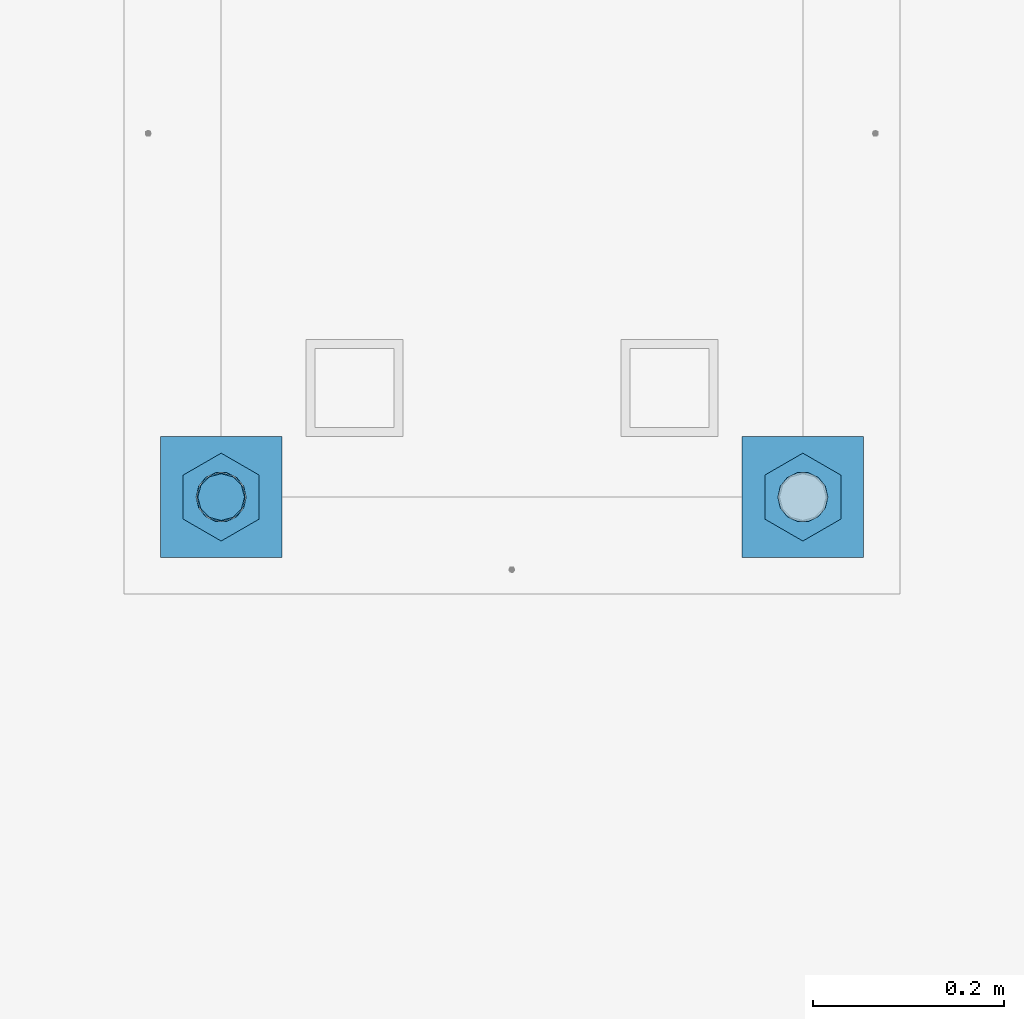
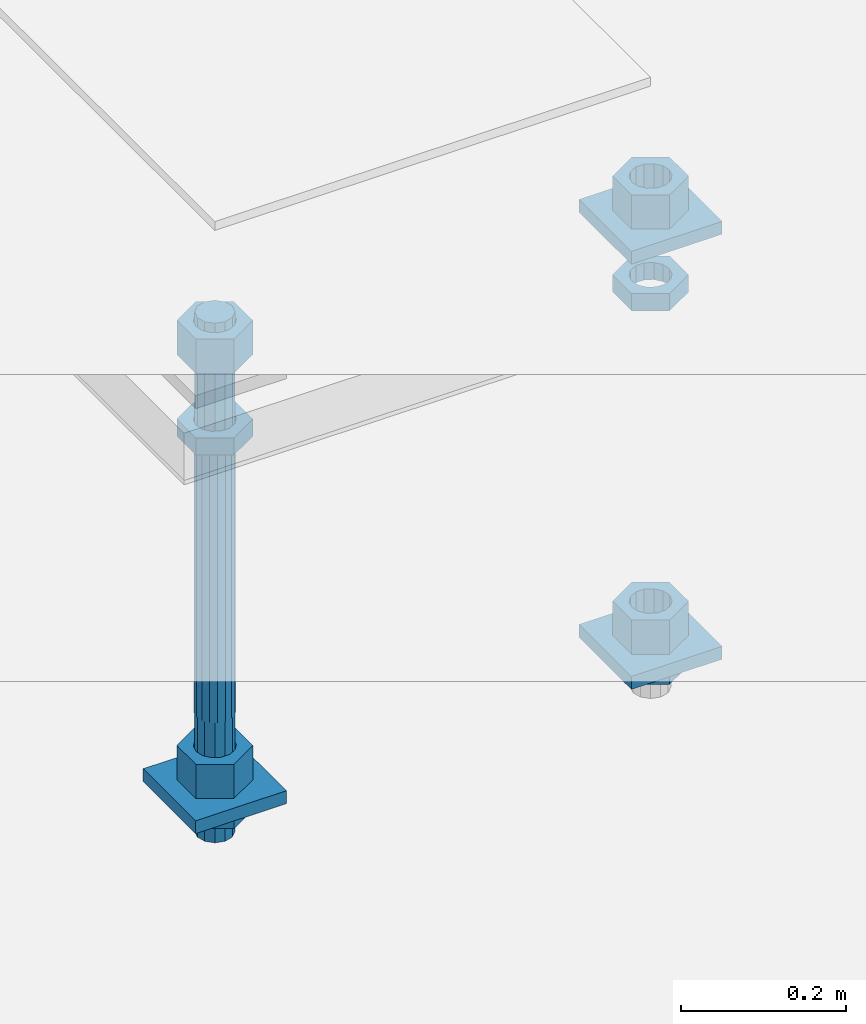
# One storey, part 2642 of 3843: 12 beams, 1 element without a shape of its own.
"""IFC2X3 building model written with IfcOpenShell, lengths in millimetres."""

import ifcopenshell
import ifcopenshell.guid

model = None  # the IFC model being written
_history = None  # IfcOwnerHistory: only IFC2X3 demands one
_inside = {}  # id of a spatial element -> (the spatial element, [elements in it])
_under = {}  # id of a project, library or spatial element -> (it, [spatial elements below it])
_declared = {}  # id of a project -> (the project, [libraries it declares])
_typed = {}  # id of a type object -> (the type object, [elements of that type])
_made_of = {}  # id of a material, layer set ... -> (it, [elements and type objects made of it])


def new_model(schema):
    """Start an empty IFC model of exactly this schema.

    Asked for "IFC4X3", IfcOpenShell would pick the latest addendum, in which some entities
    have other attributes; the version numbers below select the first issue.
    IFC2X3 requires an IfcOwnerHistory on every rooted entity: one is made here for all.
    """
    global model, _history
    if schema == "IFC4X3":
        model = ifcopenshell.file(schema_version=(4, 3, 0, 0))
    else:
        model = ifcopenshell.file(schema=schema)
    _inside.clear()
    _under.clear()
    _declared.clear()
    _typed.clear()
    _made_of.clear()
    _history = None
    if model.schema == "IFC2X3":
        org = make("IfcOrganization", Name="unknown")
        user = make(
            "IfcPersonAndOrganization",
            ThePerson=make("IfcPerson", FamilyName="unknown"),
            TheOrganization=org,
        )
        app = make(
            "IfcApplication",
            ApplicationDeveloper=org,
            Version="unknown",
            ApplicationFullName="unknown",
            ApplicationIdentifier="unknown",
        )
        _history = make(
            "IfcOwnerHistory",
            OwningUser=user,
            OwningApplication=app,
            ChangeAction="ADDED",
            CreationDate=0,
        )
    return model


def make(cls, **values):
    """One entity of the class cls with the attributes given. An attribute that is None is left unset."""
    return model.create_entity(
        cls, **{name: value for name, value in values.items() if value is not None}
    )


def rooted(cls, **values):
    """An entity with a GlobalId (a new one), such as an element, a storey or a relation."""
    return make(cls, GlobalId=ifcopenshell.guid.new(), OwnerHistory=_history, **values)


def si_unit(unit_type, name, prefix=None):
    """IfcSIUnit, for example si_unit("LENGTHUNIT", "METRE", prefix="MILLI")."""
    return make("IfcSIUnit", UnitType=unit_type, Prefix=prefix, Name=name)


def assignment(units):
    """IfcUnitAssignment: the units of a project."""
    return None if units is None else make("IfcUnitAssignment", Units=units)


def point(xyz):
    """IfcCartesianPoint."""
    return None if xyz is None else make("IfcCartesianPoint", Coordinates=xyz)


def direction(xyz):
    """IfcDirection."""
    return None if xyz is None else make("IfcDirection", DirectionRatios=xyz)


def frame(location, z_axis=None, x_axis=None):
    """IfcAxis2Placement3D, a coordinate frame: its origin and axes. An axis left out is left unset."""
    return make(
        "IfcAxis2Placement3D",
        Location=point(location),
        Axis=direction(z_axis),
        RefDirection=direction(x_axis),
    )


def origin_with_axes():
    """The frame at (0, 0, 0) with the z axis (0, 0, 1) and the x axis (1, 0, 0) written out."""
    return frame((0.0, 0.0, 0.0), z_axis=(0.0, 0.0, 1.0), x_axis=(1.0, 0.0, 0.0))


def place(relative_to, where):
    """IfcLocalPlacement: puts the frame where relative to a parent placement (None: the world)."""
    return make(
        "IfcLocalPlacement", PlacementRelTo=relative_to, RelativePlacement=where
    )


def context(
    kind, dimensions, precision=None, world=None, true_north=None, identifier=None
):
    """IfcGeometricRepresentationContext, for example the 3D "Model" context."""
    return make(
        "IfcGeometricRepresentationContext",
        ContextIdentifier=identifier,
        ContextType=kind,
        CoordinateSpaceDimension=dimensions,
        Precision=precision,
        WorldCoordinateSystem=world,
        TrueNorth=true_north,
    )


def subcontext(parent, identifier, kind, view, scale=None):
    """IfcGeometricRepresentationSubContext, for example "Body" below "Model"."""
    return make(
        "IfcGeometricRepresentationSubContext",
        ContextIdentifier=identifier,
        ContextType=kind,
        ParentContext=parent,
        TargetScale=scale,
        TargetView=view,
    )


def project(units=None, contexts=None):
    """IfcProject with its units and contexts."""
    return rooted(
        "IfcProject",
        Name="project",
        RepresentationContexts=contexts,
        UnitsInContext=assignment(units),
    )


def spatial(cls, under=None, at=None, **own):
    """A site, building, storey or space (cls), placed at a placement, below another one or the project."""
    s = rooted(cls, ObjectPlacement=at, **own)
    if under is not None:
        _under.setdefault(under.id(), (under, []))[1].append(s)
    return s


def faces_of(points, faces, orient=None, outer=None):
    """IfcFace entities. A face is a list of loops; a loop is a list of indices into points, from 0.

    orient and outer hold one flag for each loop. By default every Orientation is true, the
    first loop of a face is its IfcFaceOuterBound and the others are IfcFaceBound.
    """
    made = []
    for i, loops in enumerate(faces):
        bounds = []
        for j, loop in enumerate(loops):
            is_outer = j == 0 if outer is None else outer[i][j]
            bounds.append(
                make(
                    "IfcFaceOuterBound" if is_outer else "IfcFaceBound",
                    Bound=make("IfcPolyLoop", Polygon=[points[k] for k in loop]),
                    Orientation=True if orient is None else orient[i][j],
                )
            )
        made.append(make("IfcFace", Bounds=bounds))
    return made


def faceted_brep(points, faces, orient=None, outer=None, voids=None):
    """IfcFacetedBrep: a solid bounded by flat faces; with voids (closed shells), ...WithVoids."""
    shared = [point(p) for p in points]
    hull = make("IfcClosedShell", CfsFaces=faces_of(shared, faces, orient, outer))
    if voids is None:
        return make("IfcFacetedBrep", Outer=hull)
    return make(
        "IfcFacetedBrepWithVoids",
        Outer=hull,
        Voids=[
            make(cls, CfsFaces=faces_of(shared, fs, o, b)) for cls, fs, o, b in voids
        ],
    )


def shape(context_of_items, identifier, shape_type, items):
    """IfcShapeRepresentation: the items that make up one representation, for example the "Body"."""
    return make(
        "IfcShapeRepresentation",
        ContextOfItems=context_of_items,
        RepresentationIdentifier=identifier,
        RepresentationType=shape_type,
        Items=items,
    )


def material(Name=None, Category=None):
    """IfcMaterial."""
    return make("IfcMaterial", Name=Name, Category=Category)


def made_of(thing, what):
    """Note that an element or type object is made of a material, layer set ...; save() writes the relation."""
    if what is not None:
        _made_of.setdefault(what.id(), (what, []))[1].append(thing)
    return thing


def type_object(cls, material=None, **own):
    """A type object (cls), such as IfcWallType, which elements share."""
    return made_of(rooted(cls, **own), material)


def element(
    cls,
    number,
    at=None,
    inside=None,
    cuts=None,
    type_object=None,
    material=None,
    context=None,
    identifier="Body",
    shape_type=None,
    held_by="IfcProductDefinitionShape",
    body=None,
    shapes=None,
    **own,
):
    """One element of the class cls, such as IfcWall. Its Tag is "e" and its number.

    at: its placement. inside: the storey or other place that contains it. cuts: it is an
    opening in that element (IfcRelVoidsElement). A single representation is given by context,
    identifier, shape_type and body (its items); several are given by shapes. held_by: the class
    of the entity that holds the representations. save() writes the other relations.
    """
    e = rooted(cls, Tag="e%d" % number, ObjectPlacement=at, **own)
    if body is not None:
        shapes = [shape(context, identifier, shape_type, body)]
    if shapes is not None:
        e.Representation = make(held_by, Representations=shapes)
    if inside is not None:
        _inside.setdefault(inside.id(), (inside, []))[1].append(e)
    if cuts is not None:
        rooted(
            "IfcRelVoidsElement", RelatingBuildingElement=cuts, RelatedOpeningElement=e
        )
    if type_object is not None:
        _typed.setdefault(type_object.id(), (type_object, []))[1].append(e)
    return made_of(e, material)


def aggregate(whole, parts):
    """IfcRelAggregates: a whole, such as a stair, and the parts it consists of."""
    return rooted("IfcRelAggregates", RelatingObject=whole, RelatedObjects=parts)


def save(model, path):
    """Write the relations noted so far, then the file.

    IfcRelAggregates (storeys below a building ...), IfcRelContainedInSpatialStructure (elements
    in a storey), IfcRelDefinesByType, IfcRelAssociatesMaterial and IfcRelDeclares: one each for
    every whole, place, type object, material and project.
    """
    for whole, parts in _under.values():
        aggregate(whole, parts)
    for where, things in _inside.values():
        rooted(
            "IfcRelContainedInSpatialStructure",
            RelatedElements=things,
            RelatingStructure=where,
        )
    for kind, things in _typed.values():
        rooted("IfcRelDefinesByType", RelatedObjects=things, RelatingType=kind)
    for what, things in _made_of.values():
        rooted("IfcRelAssociatesMaterial", RelatedObjects=things, RelatingMaterial=what)
    for by, libraries in _declared.values():
        rooted("IfcRelDeclares", RelatingContext=by, RelatedDefinitions=libraries)
    model.write(path)


model = new_model("IFC2X3")

# Units and contexts
model_context = context("Model", 3, precision=1e-05, world=origin_with_axes())
body_context = subcontext(model_context, "Body", "Model", "MODEL_VIEW")
ifc_project = project(units=[si_unit("LENGTHUNIT", "METRE", prefix="MILLI"), si_unit("AREAUNIT", "SQUARE_METRE"), si_unit("VOLUMEUNIT", "CUBIC_METRE"), si_unit("MASSUNIT", "GRAM", prefix="KILO"), si_unit("TIMEUNIT", "SECOND"), si_unit("PLANEANGLEUNIT", "RADIAN"), si_unit("SOLIDANGLEUNIT", "STERADIAN"), si_unit("THERMODYNAMICTEMPERATUREUNIT", "DEGREE_CELSIUS"), si_unit("LUMINOUSINTENSITYUNIT", "LUMEN")], contexts=[model_context])

# Site, building, storey
site_placement = place(None, origin_with_axes())
site = spatial("IfcSite", under=ifc_project, at=site_placement, CompositionType="ELEMENT")
building_placement = place(site_placement, origin_with_axes())
building = spatial("IfcBuilding", under=site, at=building_placement, Name="Undefined", CompositionType="ELEMENT")
storey_placement = place(building_placement, origin_with_axes())
storey = spatial("IfcBuildingStorey", under=building, at=storey_placement, Name="Undefined", CompositionType="ELEMENT", Elevation=0.0)

# Assembly, beams
assembly_placement = place(storey_placement, origin_with_axes())
assembly = element("IfcElementAssembly", 1, at=assembly_placement, inside=storey, Name="TEMPLATE", AssemblyPlace="NOTDEFINED", PredefinedType="RIGID_FRAME")
ifc_material_1 = material(Name="STEEL/A36")
beam_type_1 = type_object("IfcBeamType", PredefinedType="NOTDEFINED")
beam_1_placement = place(assembly_placement, frame((116471.7, 10121.9, 29873.575), z_axis=(0.0, 1.0, 0.0), x_axis=(-1.0, 0.0, 0.0)))
beam_1 = element("IfcBeam", 2, at=beam_1_placement, type_object=beam_type_1, material=ifc_material_1, Name="WASHER_PLATE", context=body_context, shape_type="Brep", body=[
    faceted_brep([(0.0, 9.52500000000146, -63.5), (0.0, 9.52500000000146, 63.5), (127.0, 9.52500000000146, 63.5), (127.0, 9.52500000000146, -63.5), (0.0, -9.52500000000146, 63.5), (127.0, -9.52500000000146, 63.5), (0.0, -9.52500000000146, -63.5), (127.0, -9.52500000000146, -63.5)], [[[0, 1, 2, 3]], [[1, 4, 5, 2]], [[4, 6, 7, 5]], [[6, 0, 3, 7]], [[5, 7, 3, 2]], [[6, 4, 1, 0]]]),
])
beam_2_placement = place(assembly_placement, frame((115862.099998474, 10121.9, 29244.925), z_axis=(0.0, 1.0, 0.0), x_axis=(-1.0, 0.0, 0.0)))
beam_2 = element("IfcBeam", 3, at=beam_2_placement, type_object=beam_type_1, material=ifc_material_1, Name="WASHER_PLATE", context=body_context, shape_type="Brep", body=[
    faceted_brep([(0.0, 9.52500000000146, -63.5), (0.0, 9.52500000000146, 63.5), (127.0, 9.52500000000146, 63.5), (127.0, 9.52500000000146, -63.5), (0.0, -9.52500000000146, 63.5), (127.0, -9.52500000000146, 63.5), (0.0, -9.52500000000146, -63.5), (127.0, -9.52500000000146, -63.5)], [[[0, 1, 2, 3]], [[1, 4, 5, 2]], [[4, 6, 7, 5]], [[6, 0, 3, 7]], [[5, 7, 3, 2]], [[6, 4, 1, 0]]]),
])
beam_3_placement = place(assembly_placement, frame((116471.7, 10121.9, 29244.925), z_axis=(0.0, 1.0, 0.0), x_axis=(-1.0, 0.0, 0.0)))
beam_3 = element("IfcBeam", 4, at=beam_3_placement, type_object=beam_type_1, material=ifc_material_1, Name="WASHER_PLATE", context=body_context, shape_type="Brep", body=[
    faceted_brep([(0.0, 9.52500000000146, -63.5), (0.0, 9.52500000000146, 63.5), (127.0, 9.52500000000146, 63.5), (127.0, 9.52500000000146, -63.5), (0.0, -9.52500000000146, 63.5), (127.0, -9.52500000000146, 63.5), (0.0, -9.52500000000146, -63.5), (127.0, -9.52500000000146, -63.5)], [[[0, 1, 2, 3]], [[1, 4, 5, 2]], [[4, 6, 7, 5]], [[6, 0, 3, 7]], [[5, 7, 3, 2]], [[6, 4, 1, 0]]]),
])
beam_type_2 = type_object("IfcBeamType", Name="2_HALF_NUT", PredefinedType="NOTDEFINED")
beam_4_placement = place(assembly_placement, frame((115798.599998474, 10121.9, 29787.85), z_axis=(-1.0, 0.0, 0.0), x_axis=(0.0, 0.0, -1.0)))
beam_4 = element("IfcBeam", 5, at=beam_4_placement, type_object=beam_type_2, material=ifc_material_1, Name="NUT", ObjectType="2_HALF_NUT", context=body_context, shape_type="Brep", body=[
    faceted_brep([(0.0, -46.0369987487793, 0.0), (0.0, -23.0184993743896, -39.869213104248), (25.4000000000015, -23.0184993743896, -39.869213104248), (25.4000000000015, -46.0369987487793, 0.0), (0.0, 23.0184993743896, -39.869213104248), (25.4000000000015, 23.0184993743896, -39.869213104248), (0.0, 46.0369987487793, 0.0), (25.4000000000015, 46.0369987487793, 0.0), (0.0, 23.0184993743896, 39.869213104248), (25.4000000000015, 23.0184993743896, 39.869213104248), (0.0, -23.0184993743896, 39.869213104248), (25.4000000000015, -23.0184993743896, 39.869213104248), (0.0, 0.0, 26.1940002441406), (0.0, 11.3650617044477, 23.5999013092805), (25.4000000000015, 11.3650617044477, 23.5999013092805), (25.4000000000015, 0.0, 26.1940002441406), (0.0, 20.4791109456419, 16.3316083006721), (25.4000000000015, 20.4791109456419, 16.3316083006721), (0.0, 25.5370200498292, 5.82867859874386), (25.4000000000015, 25.5370200498292, 5.82867859874386), (0.0, 25.5370200498292, -5.82867859874386), (25.4000000000015, 25.5370200498292, -5.82867859874386), (0.0, 20.4791109456419, -16.3316083006721), (25.4000000000015, 20.4791109456419, -16.3316083006721), (0.0, 11.3650617044477, -23.5999013092805), (25.4000000000015, 11.3650617044477, -23.5999013092805), (0.0, 0.0, -26.1940002441406), (25.4000000000015, 0.0, -26.1940002441406), (0.0, -11.3650617044477, -23.5999013092805), (25.4000000000015, -11.3650617044477, -23.5999013092805), (0.0, -20.4791109456419, -16.3316083006721), (25.4000000000015, -20.4791109456419, -16.3316083006721), (0.0, -25.5370200498292, -5.82867859874386), (25.4000000000015, -25.5370200498292, -5.82867859874386), (0.0, -25.5370200498292, 5.82867859874386), (25.4000000000015, -25.5370200498292, 5.82867859874386), (0.0, -20.4791109456419, 16.3316083006721), (25.4000000000015, -20.4791109456419, 16.3316083006721), (0.0, -11.3650617044477, 23.5999013092805), (25.4000000000015, -11.3650617044477, 23.5999013092805)], [[[0, 1, 2, 3]], [[1, 4, 5, 2]], [[4, 6, 7, 5]], [[6, 8, 9, 7]], [[8, 10, 11, 9]], [[10, 0, 3, 11]], [[12, 13, 14, 15]], [[13, 16, 17, 14]], [[16, 18, 19, 17]], [[18, 20, 21, 19]], [[20, 22, 23, 21]], [[22, 24, 25, 23]], [[24, 26, 27, 25]], [[26, 28, 29, 27]], [[28, 30, 31, 29]], [[30, 32, 33, 31]], [[32, 34, 35, 33]], [[34, 36, 37, 35]], [[36, 38, 39, 37]], [[38, 12, 15, 39]], [[5, 7, 9, 11, 3, 2], [17, 19, 21, 23, 25, 27, 29, 31, 33, 35, 37, 39, 15, 14]], [[10, 8, 6, 4, 1, 0], [38, 36, 34, 32, 30, 28, 26, 24, 22, 20, 18, 16, 13, 12]]]),
])
beam_5_placement = place(assembly_placement, frame((115798.599998474, 10121.9, 29235.4), z_axis=(-1.0, 0.0, 0.0), x_axis=(0.0, 0.0, -1.0)))
beam_5 = element("IfcBeam", 6, at=beam_5_placement, type_object=beam_type_2, material=ifc_material_1, Name="NUT", ObjectType="2_HALF_NUT", context=body_context, shape_type="Brep", body=[
    faceted_brep([(0.0, -46.0369987487793, 0.0), (0.0, -23.0184993743896, -39.869213104248), (25.4000000000015, -23.0184993743896, -39.869213104248), (25.4000000000015, -46.0369987487793, 0.0), (0.0, 23.0184993743896, -39.869213104248), (25.4000000000015, 23.0184993743896, -39.869213104248), (0.0, 46.0369987487793, 0.0), (25.4000000000015, 46.0369987487793, 0.0), (0.0, 23.0184993743896, 39.869213104248), (25.4000000000015, 23.0184993743896, 39.869213104248), (0.0, -23.0184993743896, 39.869213104248), (25.4000000000015, -23.0184993743896, 39.869213104248), (0.0, 0.0, 26.1940002441406), (0.0, 11.3650617044477, 23.5999013092805), (25.4000000000015, 11.3650617044477, 23.5999013092805), (25.4000000000015, 0.0, 26.1940002441406), (0.0, 20.4791109456419, 16.3316083006721), (25.4000000000015, 20.4791109456419, 16.3316083006721), (0.0, 25.5370200498292, 5.82867859874386), (25.4000000000015, 25.5370200498292, 5.82867859874386), (0.0, 25.5370200498292, -5.82867859874386), (25.4000000000015, 25.5370200498292, -5.82867859874386), (0.0, 20.4791109456419, -16.3316083006721), (25.4000000000015, 20.4791109456419, -16.3316083006721), (0.0, 11.3650617044477, -23.5999013092805), (25.4000000000015, 11.3650617044477, -23.5999013092805), (0.0, 0.0, -26.1940002441406), (25.4000000000015, 0.0, -26.1940002441406), (0.0, -11.3650617044477, -23.5999013092805), (25.4000000000015, -11.3650617044477, -23.5999013092805), (0.0, -20.4791109456419, -16.3316083006721), (25.4000000000015, -20.4791109456419, -16.3316083006721), (0.0, -25.5370200498292, -5.82867859874386), (25.4000000000015, -25.5370200498292, -5.82867859874386), (0.0, -25.5370200498292, 5.82867859874386), (25.4000000000015, -25.5370200498292, 5.82867859874386), (0.0, -20.4791109456419, 16.3316083006721), (25.4000000000015, -20.4791109456419, 16.3316083006721), (0.0, -11.3650617044477, 23.5999013092805), (25.4000000000015, -11.3650617044477, 23.5999013092805)], [[[0, 1, 2, 3]], [[1, 4, 5, 2]], [[4, 6, 7, 5]], [[6, 8, 9, 7]], [[8, 10, 11, 9]], [[10, 0, 3, 11]], [[12, 13, 14, 15]], [[13, 16, 17, 14]], [[16, 18, 19, 17]], [[18, 20, 21, 19]], [[20, 22, 23, 21]], [[22, 24, 25, 23]], [[24, 26, 27, 25]], [[26, 28, 29, 27]], [[28, 30, 31, 29]], [[30, 32, 33, 31]], [[32, 34, 35, 33]], [[34, 36, 37, 35]], [[36, 38, 39, 37]], [[38, 12, 15, 39]], [[5, 7, 9, 11, 3, 2], [17, 19, 21, 23, 25, 27, 29, 31, 33, 35, 37, 39, 15, 14]], [[10, 8, 6, 4, 1, 0], [38, 36, 34, 32, 30, 28, 26, 24, 22, 20, 18, 16, 13, 12]]]),
])
beam_6_placement = place(assembly_placement, frame((116408.2, 10121.9, 29787.85), z_axis=(-1.0, 0.0, 0.0), x_axis=(0.0, 0.0, -1.0)))
beam_6 = element("IfcBeam", 7, at=beam_6_placement, type_object=beam_type_2, material=ifc_material_1, Name="NUT", ObjectType="2_HALF_NUT", context=body_context, shape_type="Brep", body=[
    faceted_brep([(0.0, -46.0369987487793, 0.0), (0.0, -23.0184993743896, -39.869213104248), (25.4000000000015, -23.0184993743896, -39.869213104248), (25.4000000000015, -46.0369987487793, 0.0), (0.0, 23.0184993743896, -39.869213104248), (25.4000000000015, 23.0184993743896, -39.869213104248), (0.0, 46.0369987487793, 0.0), (25.4000000000015, 46.0369987487793, 0.0), (0.0, 23.0184993743896, 39.869213104248), (25.4000000000015, 23.0184993743896, 39.869213104248), (0.0, -23.0184993743896, 39.869213104248), (25.4000000000015, -23.0184993743896, 39.869213104248), (0.0, 0.0, 26.1940002441406), (0.0, 11.3650617044477, 23.5999013092805), (25.4000000000015, 11.3650617044477, 23.5999013092805), (25.4000000000015, 0.0, 26.1940002441406), (0.0, 20.4791109456419, 16.3316083006721), (25.4000000000015, 20.4791109456419, 16.3316083006721), (0.0, 25.5370200498292, 5.82867859874386), (25.4000000000015, 25.5370200498292, 5.82867859874386), (0.0, 25.5370200498292, -5.82867859874386), (25.4000000000015, 25.5370200498292, -5.82867859874386), (0.0, 20.4791109456419, -16.3316083006721), (25.4000000000015, 20.4791109456419, -16.3316083006721), (0.0, 11.3650617044477, -23.5999013092805), (25.4000000000015, 11.3650617044477, -23.5999013092805), (0.0, 0.0, -26.1940002441406), (25.4000000000015, 0.0, -26.1940002441406), (0.0, -11.3650617044477, -23.5999013092805), (25.4000000000015, -11.3650617044477, -23.5999013092805), (0.0, -20.4791109456419, -16.3316083006721), (25.4000000000015, -20.4791109456419, -16.3316083006721), (0.0, -25.5370200498292, -5.82867859874386), (25.4000000000015, -25.5370200498292, -5.82867859874386), (0.0, -25.5370200498292, 5.82867859874386), (25.4000000000015, -25.5370200498292, 5.82867859874386), (0.0, -20.4791109456419, 16.3316083006721), (25.4000000000015, -20.4791109456419, 16.3316083006721), (0.0, -11.3650617044477, 23.5999013092805), (25.4000000000015, -11.3650617044477, 23.5999013092805)], [[[0, 1, 2, 3]], [[1, 4, 5, 2]], [[4, 6, 7, 5]], [[6, 8, 9, 7]], [[8, 10, 11, 9]], [[10, 0, 3, 11]], [[12, 13, 14, 15]], [[13, 16, 17, 14]], [[16, 18, 19, 17]], [[18, 20, 21, 19]], [[20, 22, 23, 21]], [[22, 24, 25, 23]], [[24, 26, 27, 25]], [[26, 28, 29, 27]], [[28, 30, 31, 29]], [[30, 32, 33, 31]], [[32, 34, 35, 33]], [[34, 36, 37, 35]], [[36, 38, 39, 37]], [[38, 12, 15, 39]], [[5, 7, 9, 11, 3, 2], [17, 19, 21, 23, 25, 27, 29, 31, 33, 35, 37, 39, 15, 14]], [[10, 8, 6, 4, 1, 0], [38, 36, 34, 32, 30, 28, 26, 24, 22, 20, 18, 16, 13, 12]]]),
])
beam_7_placement = place(assembly_placement, frame((116408.2, 10121.9, 29235.4), z_axis=(-1.0, 0.0, 0.0), x_axis=(0.0, 0.0, -1.0)))
beam_7 = element("IfcBeam", 8, at=beam_7_placement, type_object=beam_type_2, material=ifc_material_1, Name="NUT", ObjectType="2_HALF_NUT", context=body_context, shape_type="Brep", body=[
    faceted_brep([(0.0, -46.0369987487793, 0.0), (0.0, -23.0184993743896, -39.869213104248), (25.4000000000015, -23.0184993743896, -39.869213104248), (25.4000000000015, -46.0369987487793, 0.0), (0.0, 23.0184993743896, -39.869213104248), (25.4000000000015, 23.0184993743896, -39.869213104248), (0.0, 46.0369987487793, 0.0), (25.4000000000015, 46.0369987487793, 0.0), (0.0, 23.0184993743896, 39.869213104248), (25.4000000000015, 23.0184993743896, 39.869213104248), (0.0, -23.0184993743896, 39.869213104248), (25.4000000000015, -23.0184993743896, 39.869213104248), (0.0, 0.0, 26.1940002441406), (0.0, 11.3650617044477, 23.5999013092805), (25.4000000000015, 11.3650617044477, 23.5999013092805), (25.4000000000015, 0.0, 26.1940002441406), (0.0, 20.4791109456419, 16.3316083006721), (25.4000000000015, 20.4791109456419, 16.3316083006721), (0.0, 25.5370200498292, 5.82867859874386), (25.4000000000015, 25.5370200498292, 5.82867859874386), (0.0, 25.5370200498292, -5.82867859874386), (25.4000000000015, 25.5370200498292, -5.82867859874386), (0.0, 20.4791109456419, -16.3316083006721), (25.4000000000015, 20.4791109456419, -16.3316083006721), (0.0, 11.3650617044477, -23.5999013092805), (25.4000000000015, 11.3650617044477, -23.5999013092805), (0.0, 0.0, -26.1940002441406), (25.4000000000015, 0.0, -26.1940002441406), (0.0, -11.3650617044477, -23.5999013092805), (25.4000000000015, -11.3650617044477, -23.5999013092805), (0.0, -20.4791109456419, -16.3316083006721), (25.4000000000015, -20.4791109456419, -16.3316083006721), (0.0, -25.5370200498292, -5.82867859874386), (25.4000000000015, -25.5370200498292, -5.82867859874386), (0.0, -25.5370200498292, 5.82867859874386), (25.4000000000015, -25.5370200498292, 5.82867859874386), (0.0, -20.4791109456419, 16.3316083006721), (25.4000000000015, -20.4791109456419, 16.3316083006721), (0.0, -11.3650617044477, 23.5999013092805), (25.4000000000015, -11.3650617044477, 23.5999013092805)], [[[0, 1, 2, 3]], [[1, 4, 5, 2]], [[4, 6, 7, 5]], [[6, 8, 9, 7]], [[8, 10, 11, 9]], [[10, 0, 3, 11]], [[12, 13, 14, 15]], [[13, 16, 17, 14]], [[16, 18, 19, 17]], [[18, 20, 21, 19]], [[20, 22, 23, 21]], [[22, 24, 25, 23]], [[24, 26, 27, 25]], [[26, 28, 29, 27]], [[28, 30, 31, 29]], [[30, 32, 33, 31]], [[32, 34, 35, 33]], [[34, 36, 37, 35]], [[36, 38, 39, 37]], [[38, 12, 15, 39]], [[5, 7, 9, 11, 3, 2], [17, 19, 21, 23, 25, 27, 29, 31, 33, 35, 37, 39, 15, 14]], [[10, 8, 6, 4, 1, 0], [38, 36, 34, 32, 30, 28, 26, 24, 22, 20, 18, 16, 13, 12]]]),
])
beam_type_3 = type_object("IfcBeamType", Name="2_HEAVY_HEX_NUT", PredefinedType="NOTDEFINED")
beam_8_placement = place(assembly_placement, frame((115798.599998474, 10121.9, 29933.9), z_axis=(-1.0, 0.0, 0.0), x_axis=(0.0, 0.0, -1.0)))
beam_8 = element("IfcBeam", 9, at=beam_8_placement, type_object=beam_type_3, material=ifc_material_1, Name="NUT", ObjectType="2_HEAVY_HEX_NUT", context=body_context, shape_type="Brep", body=[
    faceted_brep([(0.0, -46.0369987487793, 0.0), (0.0, -23.0184993743896, -39.869213104248), (50.7999999999993, -23.0184993743896, -39.869213104248), (50.7999999999993, -46.0369987487793, 0.0), (0.0, 23.0184993743896, -39.869213104248), (50.7999999999993, 23.0184993743896, -39.869213104248), (0.0, 46.0369987487793, 0.0), (50.7999999999993, 46.0369987487793, 0.0), (0.0, 23.0184993743896, 39.869213104248), (50.7999999999993, 23.0184993743896, 39.869213104248), (0.0, -23.0184993743896, 39.869213104248), (50.7999999999993, -23.0184993743896, 39.869213104248), (0.0, 0.0, 26.1940002441406), (0.0, 11.3650617044477, 23.5999013092805), (50.7999999999993, 11.3650617044477, 23.5999013092805), (50.7999999999993, 0.0, 26.1940002441406), (0.0, 20.4791109456419, 16.3316083006721), (50.7999999999993, 20.4791109456419, 16.3316083006721), (0.0, 25.5370200498292, 5.82867859874386), (50.7999999999993, 25.5370200498292, 5.82867859874386), (0.0, 25.5370200498292, -5.82867859874386), (50.7999999999993, 25.5370200498292, -5.82867859874386), (0.0, 20.4791109456419, -16.3316083006721), (50.7999999999993, 20.4791109456419, -16.3316083006721), (0.0, 11.3650617044477, -23.5999013092805), (50.7999999999993, 11.3650617044477, -23.5999013092805), (0.0, 0.0, -26.1940002441406), (50.7999999999993, 0.0, -26.1940002441406), (0.0, -11.3650617044477, -23.5999013092805), (50.7999999999993, -11.3650617044477, -23.5999013092805), (0.0, -20.4791109456419, -16.3316083006721), (50.7999999999993, -20.4791109456419, -16.3316083006721), (0.0, -25.5370200498292, -5.82867859874386), (50.7999999999993, -25.5370200498292, -5.82867859874386), (0.0, -25.5370200498292, 5.82867859874386), (50.7999999999993, -25.5370200498292, 5.82867859874386), (0.0, -20.4791109456419, 16.3316083006721), (50.7999999999993, -20.4791109456419, 16.3316083006721), (0.0, -11.3650617044477, 23.5999013092805), (50.7999999999993, -11.3650617044477, 23.5999013092805)], [[[0, 1, 2, 3]], [[1, 4, 5, 2]], [[4, 6, 7, 5]], [[6, 8, 9, 7]], [[8, 10, 11, 9]], [[10, 0, 3, 11]], [[12, 13, 14, 15]], [[13, 16, 17, 14]], [[16, 18, 19, 17]], [[18, 20, 21, 19]], [[20, 22, 23, 21]], [[22, 24, 25, 23]], [[24, 26, 27, 25]], [[26, 28, 29, 27]], [[28, 30, 31, 29]], [[30, 32, 33, 31]], [[32, 34, 35, 33]], [[34, 36, 37, 35]], [[36, 38, 39, 37]], [[38, 12, 15, 39]], [[5, 7, 9, 11, 3, 2], [17, 19, 21, 23, 25, 27, 29, 31, 33, 35, 37, 39, 15, 14]], [[10, 8, 6, 4, 1, 0], [38, 36, 34, 32, 30, 28, 26, 24, 22, 20, 18, 16, 13, 12]]]),
])
beam_9_placement = place(assembly_placement, frame((115798.599998474, 10121.9, 29305.25), z_axis=(-1.0, 0.0, 0.0), x_axis=(0.0, 0.0, -1.0)))
beam_9 = element("IfcBeam", 10, at=beam_9_placement, type_object=beam_type_3, material=ifc_material_1, Name="NUT", ObjectType="2_HEAVY_HEX_NUT", context=body_context, shape_type="Brep", body=[
    faceted_brep([(0.0, -46.0369987487793, 0.0), (0.0, -23.0184993743896, -39.869213104248), (50.7999999999993, -23.0184993743896, -39.869213104248), (50.7999999999993, -46.0369987487793, 0.0), (0.0, 23.0184993743896, -39.869213104248), (50.7999999999993, 23.0184993743896, -39.869213104248), (0.0, 46.0369987487793, 0.0), (50.7999999999993, 46.0369987487793, 0.0), (0.0, 23.0184993743896, 39.869213104248), (50.7999999999993, 23.0184993743896, 39.869213104248), (0.0, -23.0184993743896, 39.869213104248), (50.7999999999993, -23.0184993743896, 39.869213104248), (0.0, 0.0, 26.1940002441406), (0.0, 11.3650617044477, 23.5999013092805), (50.7999999999993, 11.3650617044477, 23.5999013092805), (50.7999999999993, 0.0, 26.1940002441406), (0.0, 20.4791109456419, 16.3316083006721), (50.7999999999993, 20.4791109456419, 16.3316083006721), (0.0, 25.5370200498292, 5.82867859874386), (50.7999999999993, 25.5370200498292, 5.82867859874386), (0.0, 25.5370200498292, -5.82867859874386), (50.7999999999993, 25.5370200498292, -5.82867859874386), (0.0, 20.4791109456419, -16.3316083006721), (50.7999999999993, 20.4791109456419, -16.3316083006721), (0.0, 11.3650617044477, -23.5999013092805), (50.7999999999993, 11.3650617044477, -23.5999013092805), (0.0, 0.0, -26.1940002441406), (50.7999999999993, 0.0, -26.1940002441406), (0.0, -11.3650617044477, -23.5999013092805), (50.7999999999993, -11.3650617044477, -23.5999013092805), (0.0, -20.4791109456419, -16.3316083006721), (50.7999999999993, -20.4791109456419, -16.3316083006721), (0.0, -25.5370200498292, -5.82867859874386), (50.7999999999993, -25.5370200498292, -5.82867859874386), (0.0, -25.5370200498292, 5.82867859874386), (50.7999999999993, -25.5370200498292, 5.82867859874386), (0.0, -20.4791109456419, 16.3316083006721), (50.7999999999993, -20.4791109456419, 16.3316083006721), (0.0, -11.3650617044477, 23.5999013092805), (50.7999999999993, -11.3650617044477, 23.5999013092805)], [[[0, 1, 2, 3]], [[1, 4, 5, 2]], [[4, 6, 7, 5]], [[6, 8, 9, 7]], [[8, 10, 11, 9]], [[10, 0, 3, 11]], [[12, 13, 14, 15]], [[13, 16, 17, 14]], [[16, 18, 19, 17]], [[18, 20, 21, 19]], [[20, 22, 23, 21]], [[22, 24, 25, 23]], [[24, 26, 27, 25]], [[26, 28, 29, 27]], [[28, 30, 31, 29]], [[30, 32, 33, 31]], [[32, 34, 35, 33]], [[34, 36, 37, 35]], [[36, 38, 39, 37]], [[38, 12, 15, 39]], [[5, 7, 9, 11, 3, 2], [17, 19, 21, 23, 25, 27, 29, 31, 33, 35, 37, 39, 15, 14]], [[10, 8, 6, 4, 1, 0], [38, 36, 34, 32, 30, 28, 26, 24, 22, 20, 18, 16, 13, 12]]]),
])
beam_10_placement = place(assembly_placement, frame((116408.2, 10121.9, 29933.9), z_axis=(-1.0, 0.0, 0.0), x_axis=(0.0, 0.0, -1.0)))
beam_10 = element("IfcBeam", 11, at=beam_10_placement, type_object=beam_type_3, material=ifc_material_1, Name="NUT", ObjectType="2_HEAVY_HEX_NUT", context=body_context, shape_type="Brep", body=[
    faceted_brep([(0.0, -46.0369987487793, 0.0), (0.0, -23.0184993743896, -39.869213104248), (50.7999999999993, -23.0184993743896, -39.869213104248), (50.7999999999993, -46.0369987487793, 0.0), (0.0, 23.0184993743896, -39.869213104248), (50.7999999999993, 23.0184993743896, -39.869213104248), (0.0, 46.0369987487793, 0.0), (50.7999999999993, 46.0369987487793, 0.0), (0.0, 23.0184993743896, 39.869213104248), (50.7999999999993, 23.0184993743896, 39.869213104248), (0.0, -23.0184993743896, 39.869213104248), (50.7999999999993, -23.0184993743896, 39.869213104248), (0.0, 0.0, 26.1940002441406), (0.0, 11.3650617044477, 23.5999013092805), (50.7999999999993, 11.3650617044477, 23.5999013092805), (50.7999999999993, 0.0, 26.1940002441406), (0.0, 20.4791109456419, 16.3316083006721), (50.7999999999993, 20.4791109456419, 16.3316083006721), (0.0, 25.5370200498292, 5.82867859874386), (50.7999999999993, 25.5370200498292, 5.82867859874386), (0.0, 25.5370200498292, -5.82867859874386), (50.7999999999993, 25.5370200498292, -5.82867859874386), (0.0, 20.4791109456419, -16.3316083006721), (50.7999999999993, 20.4791109456419, -16.3316083006721), (0.0, 11.3650617044477, -23.5999013092805), (50.7999999999993, 11.3650617044477, -23.5999013092805), (0.0, 0.0, -26.1940002441406), (50.7999999999993, 0.0, -26.1940002441406), (0.0, -11.3650617044477, -23.5999013092805), (50.7999999999993, -11.3650617044477, -23.5999013092805), (0.0, -20.4791109456419, -16.3316083006721), (50.7999999999993, -20.4791109456419, -16.3316083006721), (0.0, -25.5370200498292, -5.82867859874386), (50.7999999999993, -25.5370200498292, -5.82867859874386), (0.0, -25.5370200498292, 5.82867859874386), (50.7999999999993, -25.5370200498292, 5.82867859874386), (0.0, -20.4791109456419, 16.3316083006721), (50.7999999999993, -20.4791109456419, 16.3316083006721), (0.0, -11.3650617044477, 23.5999013092805), (50.7999999999993, -11.3650617044477, 23.5999013092805)], [[[0, 1, 2, 3]], [[1, 4, 5, 2]], [[4, 6, 7, 5]], [[6, 8, 9, 7]], [[8, 10, 11, 9]], [[10, 0, 3, 11]], [[12, 13, 14, 15]], [[13, 16, 17, 14]], [[16, 18, 19, 17]], [[18, 20, 21, 19]], [[20, 22, 23, 21]], [[22, 24, 25, 23]], [[24, 26, 27, 25]], [[26, 28, 29, 27]], [[28, 30, 31, 29]], [[30, 32, 33, 31]], [[32, 34, 35, 33]], [[34, 36, 37, 35]], [[36, 38, 39, 37]], [[38, 12, 15, 39]], [[5, 7, 9, 11, 3, 2], [17, 19, 21, 23, 25, 27, 29, 31, 33, 35, 37, 39, 15, 14]], [[10, 8, 6, 4, 1, 0], [38, 36, 34, 32, 30, 28, 26, 24, 22, 20, 18, 16, 13, 12]]]),
])
beam_11_placement = place(assembly_placement, frame((116408.2, 10121.9, 29305.25), z_axis=(-1.0, 0.0, 0.0), x_axis=(0.0, 0.0, -1.0)))
beam_11 = element("IfcBeam", 12, at=beam_11_placement, type_object=beam_type_3, material=ifc_material_1, Name="NUT", ObjectType="2_HEAVY_HEX_NUT", context=body_context, shape_type="Brep", body=[
    faceted_brep([(0.0, -46.0369987487793, 0.0), (0.0, -23.0184993743896, -39.869213104248), (50.7999999999993, -23.0184993743896, -39.869213104248), (50.7999999999993, -46.0369987487793, 0.0), (0.0, 23.0184993743896, -39.869213104248), (50.7999999999993, 23.0184993743896, -39.869213104248), (0.0, 46.0369987487793, 0.0), (50.7999999999993, 46.0369987487793, 0.0), (0.0, 23.0184993743896, 39.869213104248), (50.7999999999993, 23.0184993743896, 39.869213104248), (0.0, -23.0184993743896, 39.869213104248), (50.7999999999993, -23.0184993743896, 39.869213104248), (0.0, 0.0, 26.1940002441406), (0.0, 11.3650617044477, 23.5999013092805), (50.7999999999993, 11.3650617044477, 23.5999013092805), (50.7999999999993, 0.0, 26.1940002441406), (0.0, 20.4791109456419, 16.3316083006721), (50.7999999999993, 20.4791109456419, 16.3316083006721), (0.0, 25.5370200498292, 5.82867859874386), (50.7999999999993, 25.5370200498292, 5.82867859874386), (0.0, 25.5370200498292, -5.82867859874386), (50.7999999999993, 25.5370200498292, -5.82867859874386), (0.0, 20.4791109456419, -16.3316083006721), (50.7999999999993, 20.4791109456419, -16.3316083006721), (0.0, 11.3650617044477, -23.5999013092805), (50.7999999999993, 11.3650617044477, -23.5999013092805), (0.0, 0.0, -26.1940002441406), (50.7999999999993, 0.0, -26.1940002441406), (0.0, -11.3650617044477, -23.5999013092805), (50.7999999999993, -11.3650617044477, -23.5999013092805), (0.0, -20.4791109456419, -16.3316083006721), (50.7999999999993, -20.4791109456419, -16.3316083006721), (0.0, -25.5370200498292, -5.82867859874386), (50.7999999999993, -25.5370200498292, -5.82867859874386), (0.0, -25.5370200498292, 5.82867859874386), (50.7999999999993, -25.5370200498292, 5.82867859874386), (0.0, -20.4791109456419, 16.3316083006721), (50.7999999999993, -20.4791109456419, 16.3316083006721), (0.0, -11.3650617044477, 23.5999013092805), (50.7999999999993, -11.3650617044477, 23.5999013092805)], [[[0, 1, 2, 3]], [[1, 4, 5, 2]], [[4, 6, 7, 5]], [[6, 8, 9, 7]], [[8, 10, 11, 9]], [[10, 0, 3, 11]], [[12, 13, 14, 15]], [[13, 16, 17, 14]], [[16, 18, 19, 17]], [[18, 20, 21, 19]], [[20, 22, 23, 21]], [[22, 24, 25, 23]], [[24, 26, 27, 25]], [[26, 28, 29, 27]], [[28, 30, 31, 29]], [[30, 32, 33, 31]], [[32, 34, 35, 33]], [[34, 36, 37, 35]], [[36, 38, 39, 37]], [[38, 12, 15, 39]], [[5, 7, 9, 11, 3, 2], [17, 19, 21, 23, 25, 27, 29, 31, 33, 35, 37, 39, 15, 14]], [[10, 8, 6, 4, 1, 0], [38, 36, 34, 32, 30, 28, 26, 24, 22, 20, 18, 16, 13, 12]]]),
])
ifc_material_2 = material()
beam_type_4 = type_object("IfcBeamType", PredefinedType="NOTDEFINED")
beam_12_placement = place(assembly_placement, frame((115798.599998474, 10121.9, 29762.45), z_axis=(-1.0, 0.0, 0.0), x_axis=(0.0, 0.0, -1.0)))
beam_12 = element("IfcBeam", 13, at=beam_12_placement, type_object=beam_type_4, material=ifc_material_2, Name="ANCHOR_ROD", context=body_context, shape_type="Brep", body=[
    faceted_brep([(-184.150000000001, -21.217622392709, 12.25), (-184.150000000001, -12.2499999999854, 21.2176223927163), (-184.150000000001, 1.45519152283669e-11, 24.5), (-184.150000000001, 12.2500000000146, 21.2176223927163), (-184.150000000001, 21.2176223927381, 12.25), (-184.150000000001, 24.5000000000146, 0.0), (-184.150000000001, 21.2176223927381, -12.25), (-184.150000000001, 12.2500000000146, -21.2176223927163), (-184.150000000001, 1.45519152283669e-11, -24.5), (-184.150000000001, -12.2499999999854, -21.2176223927163), (-184.150000000001, -21.217622392709, -12.25), (-184.150000000001, -24.4999999999854, 0.0), (0.0, 24.5000000000146, 0.0), (0.0, 21.2176223927381, -12.25), (0.0, 12.2500000000146, -21.2176223927163), (0.0, 1.45519152283669e-11, -24.5), (0.0, -12.2499999999854, -21.2176223927163), (0.0, -21.217622392709, -12.25), (0.0, -24.4999999999854, 0.0), (0.0, -21.217622392709, 12.25), (0.0, -12.2499999999854, 21.2176223927163), (0.0, 1.45519152283669e-11, 24.5), (0.0, 12.2500000000146, 21.2176223927163), (0.0, 21.2176223927381, 12.25), (0.0, -23.4665401257807, 9.72015918207035), (0.0, -17.9605122421344, 17.9605122421417), (0.0, -9.72015918207762, 23.466540125788), (0.0, 0.0, 25.4000000000015), (0.0, 9.72015918207762, 23.466540125788), (0.0, 17.9605122421344, 17.9605122421417), (0.0, 23.4665401257807, 9.72015918207035), (0.0, 25.3999996185303, 0.0), (0.0, 23.4665401257807, -9.72015918207035), (0.0, 17.9605122421344, -17.9605122421417), (0.0, 9.72015918207762, -23.466540125788), (0.0, 0.0, -25.4000000000015), (0.0, -9.72015918207762, -23.466540125788), (0.0, -17.9605122421344, -17.9605122421417), (0.0, -23.4665401257807, -9.72015918207035), (0.0, -25.3999996185303, 0.0), (406.399999999998, -25.3999999999942, 0.0), (406.399999999998, -23.4665401257807, 9.72015918207035), (406.399999999998, -17.9605122421344, 17.9605122421417), (406.399999999998, -9.72015918207762, 23.466540125788), (406.399999999998, 0.0, 25.4000000000015), (406.399999999998, 9.72015918207762, 23.466540125788), (406.399999999998, 17.9605122421344, 17.9605122421417), (406.399999999998, 23.4665401257807, 9.72015918207035), (406.399999999998, 25.3999999999942, 0.0), (406.399999999998, 23.4665401257807, -9.72015918207035), (406.399999999998, 17.9605122421344, -17.9605122421417), (406.399999999998, 9.72015918207762, -23.466540125788), (406.399999999998, 0.0, -25.4000000000015), (406.399999999998, -9.72015918207762, -23.466540125788), (406.399999999998, -17.9605122421344, -17.9605122421417), (406.399999999998, -23.4665401257807, -9.72015918207035), (406.399999999998, -12.2499999999854, 21.2176223927163), (406.399999999998, 1.45519152283669e-11, 24.5), (406.399999999998, 12.2500000000146, 21.2176223927163), (406.399999999998, 21.2176223927381, 12.25), (406.399999999998, 24.5000000000146, 0.0), (406.399999999998, 21.2176223927381, -12.25), (406.399999999998, 12.2500000000146, -21.2176223927163), (406.399999999998, 1.45519152283669e-11, -24.5), (406.399999999998, -12.2499999999854, -21.2176223927163), (406.399999999998, -21.217622392709, -12.25), (406.399999999998, -24.4999999999854, 0.0), (406.399999999998, -21.217622392709, 12.25), (584.200000000001, -12.2499999999854, -21.2176223927163), (584.200000000001, 1.45519152283669e-11, -24.5), (584.200000000001, 12.2500000000146, -21.2176223927163), (584.200000000001, 21.2176223927381, -12.25), (584.200000000001, 24.5000000000146, 0.0), (584.200000000001, 21.2176223927381, 12.25), (584.200000000001, 12.2500000000146, 21.2176223927163), (584.200000000001, 1.45519152283669e-11, 24.5), (584.200000000001, -12.2499999999854, 21.2176223927163), (584.200000000001, -21.217622392709, 12.25), (584.200000000001, -24.4999999999854, 0.0), (584.200000000001, -21.217622392709, -12.25)], [[[0, 1, 2, 3, 4, 5, 6, 7, 8, 9, 10, 11]], [[6, 5, 12, 13]], [[7, 6, 13, 14]], [[8, 7, 14, 15]], [[9, 8, 15, 16]], [[10, 9, 16, 17]], [[11, 10, 17, 18]], [[0, 11, 18, 19]], [[1, 0, 19, 20]], [[2, 1, 20, 21]], [[3, 2, 21, 22]], [[4, 3, 22, 23]], [[5, 4, 23, 12]], [[24, 25, 26, 27, 28, 29, 30, 31, 32, 33, 34, 35, 36, 37, 38, 39], [22, 21, 20, 19, 18, 17, 16, 15, 14, 13, 12, 23]], [[24, 39, 40, 41]], [[25, 24, 41, 42]], [[26, 25, 42, 43]], [[27, 26, 43, 44]], [[28, 27, 44, 45]], [[29, 28, 45, 46]], [[30, 29, 46, 47]], [[31, 30, 47, 48]], [[32, 31, 48, 49]], [[33, 32, 49, 50]], [[34, 33, 50, 51]], [[35, 34, 51, 52]], [[36, 35, 52, 53]], [[37, 36, 53, 54]], [[38, 37, 54, 55]], [[39, 38, 55, 40]], [[54, 53, 52, 51, 50, 49, 48, 47, 46, 45, 44, 43, 42, 41, 40, 55], [56, 57, 58, 59, 60, 61, 62, 63, 64, 65, 66, 67]], [[68, 69, 70, 71, 72, 73, 74, 75, 76, 77, 78, 79]], [[76, 75, 57, 56]], [[77, 76, 56, 67]], [[78, 77, 67, 66]], [[79, 78, 66, 65]], [[68, 79, 65, 64]], [[69, 68, 64, 63]], [[70, 69, 63, 62]], [[71, 70, 62, 61]], [[72, 71, 61, 60]], [[73, 72, 60, 59]], [[74, 73, 59, 58]], [[75, 74, 58, 57]]]),
])
aggregate(assembly, [beam_1, beam_2, beam_4, beam_8, beam_9, beam_5, beam_12, beam_3, beam_6, beam_10, beam_11, beam_7])

save(model, "model.ifc")
